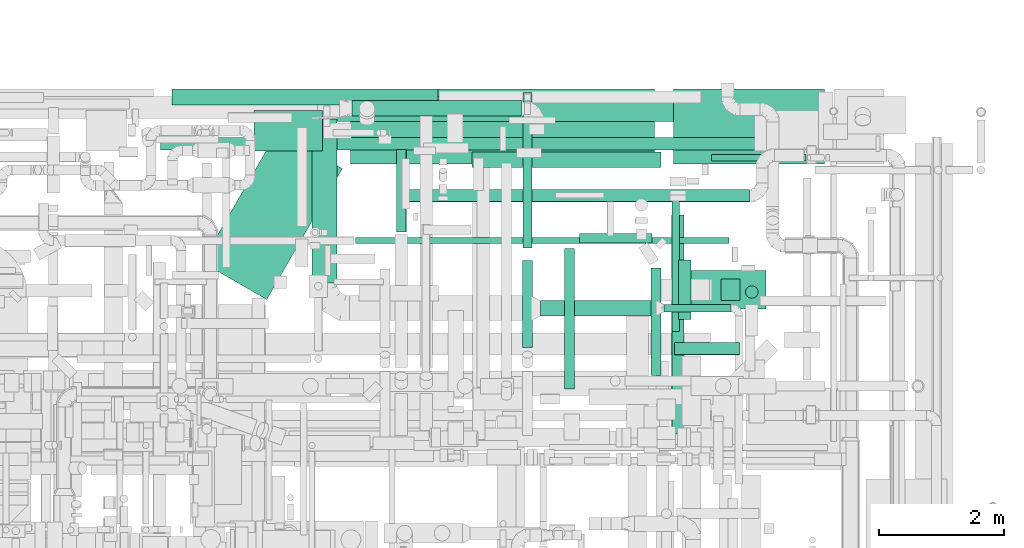
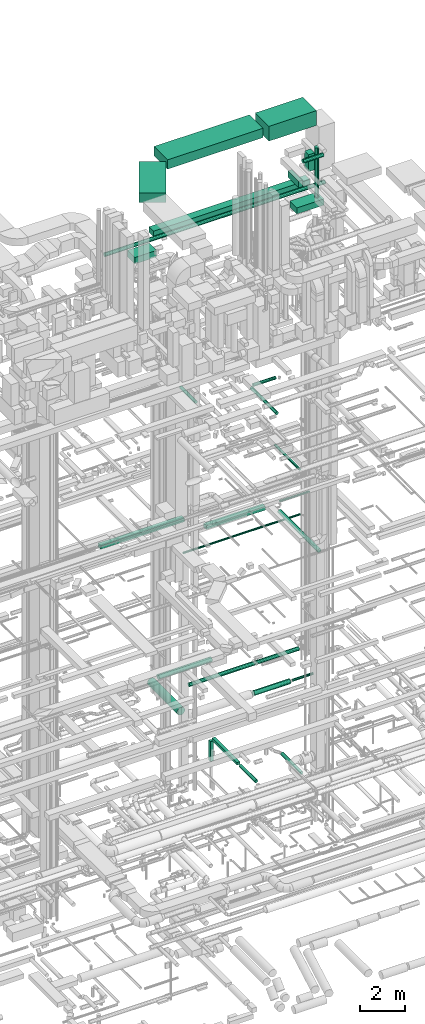
# One storey, part 77 of 337: 29 flow segments.
"""IFC2X3 building model written with IfcOpenShell, lengths in millimetres."""

from ifc_helpers import new_model, entity, si_unit, converted_unit, derived_unit, direction, frame, origin, origin_2d_with_axis, place, context, subcontext, project, spatial, rectangle, circle, extrude, type_object, element, save


model = new_model("IFC2X3")

# Units and contexts
model_context = context("Model", 3, precision=0.01, world=origin(), true_north=direction((6.12303176911189e-17, 1.0)))
body_context = subcontext(model_context, "Body", "Model", "MODEL_VIEW")
ifc_project = project(units=[si_unit("LENGTHUNIT", "METRE", prefix="MILLI"), si_unit("AREAUNIT", "SQUARE_METRE"), si_unit("VOLUMEUNIT", "CUBIC_METRE"), converted_unit("PLANEANGLEUNIT", "DEGREE", entity("IfcRatioMeasure", 0.0174532925199433), si_unit("PLANEANGLEUNIT", "RADIAN"), dimensions=[0, 0, 0, 0, 0, 0, 0]), si_unit("MASSUNIT", "GRAM", prefix="KILO"), derived_unit("MASSDENSITYUNIT", [(si_unit("MASSUNIT", "GRAM", prefix="KILO"), 1), (si_unit("LENGTHUNIT", "METRE"), -3)]), derived_unit("MOMENTOFINERTIAUNIT", [(si_unit("LENGTHUNIT", "METRE"), 4)]), si_unit("TIMEUNIT", "SECOND"), si_unit("FREQUENCYUNIT", "HERTZ"), si_unit("THERMODYNAMICTEMPERATUREUNIT", "DEGREE_CELSIUS"), derived_unit("THERMALTRANSMITTANCEUNIT", [(si_unit("MASSUNIT", "GRAM", prefix="KILO"), 1), (si_unit("THERMODYNAMICTEMPERATUREUNIT", "KELVIN"), -1), (si_unit("TIMEUNIT", "SECOND"), -3)]), derived_unit("VOLUMETRICFLOWRATEUNIT", [(si_unit("LENGTHUNIT", "METRE"), 3), (si_unit("TIMEUNIT", "SECOND"), -1)]), derived_unit("MASSFLOWRATEUNIT", [(si_unit("MASSUNIT", "GRAM", prefix="KILO"), 1), (si_unit("TIMEUNIT", "SECOND"), -1)]), derived_unit("ROTATIONALFREQUENCYUNIT", [(si_unit("TIMEUNIT", "SECOND"), -1)]), si_unit("ELECTRICCURRENTUNIT", "AMPERE"), si_unit("ELECTRICVOLTAGEUNIT", "VOLT"), si_unit("POWERUNIT", "WATT"), si_unit("FORCEUNIT", "NEWTON", prefix="KILO"), si_unit("ILLUMINANCEUNIT", "LUX"), si_unit("LUMINOUSFLUXUNIT", "LUMEN"), si_unit("LUMINOUSINTENSITYUNIT", "CANDELA"), derived_unit("USERDEFINED", [(si_unit("MASSUNIT", "GRAM", prefix="KILO"), -1), (si_unit("LENGTHUNIT", "METRE"), -2), (si_unit("TIMEUNIT", "SECOND"), 3), (si_unit("LUMINOUSFLUXUNIT", "LUMEN"), 1)]), derived_unit("LINEARVELOCITYUNIT", [(si_unit("LENGTHUNIT", "METRE"), 1), (si_unit("TIMEUNIT", "SECOND"), -1)]), si_unit("PRESSUREUNIT", "PASCAL"), derived_unit("USERDEFINED", [(si_unit("LENGTHUNIT", "METRE"), -2), (si_unit("MASSUNIT", "GRAM", prefix="KILO"), 1), (si_unit("TIMEUNIT", "SECOND"), -2)]), derived_unit("LINEARFORCEUNIT", [(si_unit("MASSUNIT", "GRAM", prefix="KILO"), 1), (si_unit("LENGTHUNIT", "METRE"), 1), (si_unit("TIMEUNIT", "SECOND"), -2), (si_unit("LENGTHUNIT", "METRE"), -1)]), derived_unit("PLANARFORCEUNIT", [(si_unit("MASSUNIT", "GRAM", prefix="KILO"), 1), (si_unit("LENGTHUNIT", "METRE"), 1), (si_unit("TIMEUNIT", "SECOND"), -2), (si_unit("LENGTHUNIT", "METRE"), -2)])], contexts=[model_context])

# Site, building, storey
site_placement = place(None, origin())
site = spatial("IfcSite", under=ifc_project, at=site_placement, CompositionType="ELEMENT")
building_placement = place(site_placement, origin())
building = spatial("IfcBuilding", under=site, at=building_placement, CompositionType="ELEMENT")
storey_placement = place(building_placement, origin())
storey = spatial("IfcBuildingStorey", under=building, at=storey_placement, CompositionType="ELEMENT", Elevation=0.0)

# Flow segments
duct_segment_type_1 = type_object("IfcDuctSegmentType", PredefinedType="NOTDEFINED")
flow_segment_1_placement = place(storey_placement, frame((58389.14, 17556.57, -925.0)))
element("IfcFlowSegment", 1, at=flow_segment_1_placement, inside=storey, type_object=duct_segment_type_1, context=body_context, shape_type="SweptSolid", body=[
    extrude(rectangle(XDim=2192.29689275001, YDim=150.000000000001, at=origin_2d_with_axis()), frame((75.0, 1096.15, 0.0), z_axis=(0.0, 0.0, 1.0), x_axis=(0.0, 1.0, 0.0)), (0.0, 0.0, 1.0), 150.0),
])
flow_segment_2_placement = place(storey_placement, frame((58389.14, 19898.87, -2155.0)))
element("IfcFlowSegment", 2, at=flow_segment_2_placement, inside=storey, type_object=duct_segment_type_1, context=body_context, shape_type="SweptSolid", body=[
    extrude(rectangle(XDim=150.000000000001, YDim=150.000000000001, at=origin_2d_with_axis()), frame((75.0, 75.0, 0.0), z_axis=(0.0, 0.0, 1.0), x_axis=(-1.0, 0.0, 0.0)), (0.0, 0.0, 1.0), 1080.00000000006),
])
flow_segment_3_placement = place(storey_placement, frame((57579.84, 18847.07, 11300.0)))
element("IfcFlowSegment", 3, at=flow_segment_3_placement, inside=storey, type_object=duct_segment_type_1, context=body_context, shape_type="SweptSolid", body=[
    extrude(rectangle(XDim=3019.0, YDim=249.999999999999, at=origin_2d_with_axis()), frame((1509.5, 125.0, 0.0), z_axis=(0.0, 0.0, 1.0), x_axis=(-1.0, 0.0, 0.0)), (0.0, 0.0, 1.0), 200.000000000002),
])
flow_segment_4_placement = place(storey_placement, frame((52773.84, 19851.06, 11300.0)))
element("IfcFlowSegment", 4, at=flow_segment_4_placement, inside=storey, type_object=duct_segment_type_1, context=body_context, shape_type="SweptSolid", body=[
    extrude(rectangle(XDim=4255.99999999999, YDim=249.999999999999, at=origin_2d_with_axis()), frame((2128.0, 125.0, 0.0)), (0.0, 0.0, 1.0), 200.000000000002),
])
flow_segment_5_placement = place(storey_placement, frame((55301.64, 19583.98, 27450.0)))
element("IfcFlowSegment", 5, at=flow_segment_5_placement, inside=storey, type_object=duct_segment_type_1, context=body_context, shape_type="SweptSolid", body=[
    extrude(rectangle(XDim=7989.17895112762, YDim=400.0, at=origin_2d_with_axis()), frame((3994.59, 200.0, 0.0)), (0.0, 0.0, 1.0), 300.000000000001),
])
flow_segment_6_placement = place(storey_placement, frame((55631.15, 18904.6, 31400.0)))
element("IfcFlowSegment", 6, at=flow_segment_6_placement, inside=storey, type_object=duct_segment_type_1, context=body_context, shape_type="SweptSolid", body=[
    extrude(rectangle(XDim=4870.01416741954, YDim=1200.0, at=origin_2d_with_axis()), frame((2435.01, 600.0, 0.0)), (0.0, 0.0, 1.0), 499.999999999999),
])
flow_segment_7_placement = place(storey_placement, frame((60801.17, 18904.6, 31100.0)))
element("IfcFlowSegment", 7, at=flow_segment_7_placement, inside=storey, type_object=duct_segment_type_1, context=body_context, shape_type="SweptSolid", body=[
    extrude(rectangle(XDim=2422.00000000014, YDim=1200.0, at=origin_2d_with_axis()), frame((1211.0, 600.0, 0.0), z_axis=(0.0, 0.0, 1.0), x_axis=(-1.0, 0.0, 0.0)), (0.0, 0.0, 1.0), 800.0),
])
flow_segment_8_placement = place(storey_placement, frame((53251.97, 16733.74, 31400.0)))
element("IfcFlowSegment", 8, at=flow_segment_8_placement, inside=storey, type_object=duct_segment_type_1, context=body_context, shape_type="SweptSolid", body=[
    extrude(rectangle(XDim=2420.09070296274, YDim=1200.0, at=origin_2d_with_axis()), frame((1124.64, 1347.93, 0.0), z_axis=(0.0, 0.0, 1.0), x_axis=(0.500000000000004, 0.866025403784436, 0.0)), (0.0, 0.0, 1.0), 499.999999999999),
])
flow_segment_9_placement = place(storey_placement, frame((54083.2, 19108.98, 26700.0)))
element("IfcFlowSegment", 9, at=flow_segment_9_placement, inside=storey, type_object=duct_segment_type_1, context=body_context, shape_type="SweptSolid", body=[
    extrude(rectangle(XDim=1100.0, YDim=650.0, at=origin_2d_with_axis()), frame((550.0, 325.0, 0.0)), (0.0, 0.0, 1.0), 349.999999999998),
])
flow_segment_10_placement = place(storey_placement, frame((60885.21, 16580.46, 28547.0)))
element("IfcFlowSegment", 10, at=flow_segment_10_placement, inside=storey, type_object=duct_segment_type_1, context=body_context, shape_type="SweptSolid", body=[
    extrude(rectangle(XDim=1400.0, YDim=620.0, at=origin_2d_with_axis()), frame((700.0, 310.0, 0.0)), (0.0, 0.0, 1.0), 330.000000000003),
])
duct_segment_type_2 = type_object("IfcDuctSegmentType", PredefinedType="NOTDEFINED")
flow_segment_11_placement = place(storey_placement, frame((60437.78, 15518.96, -931.6)))
element("IfcFlowSegment", 11, at=flow_segment_11_placement, inside=storey, type_object=duct_segment_type_2, context=body_context, shape_type="SweptSolid", body=[
    extrude(circle(Radius=80.0, at=origin_2d_with_axis()), frame((81.6, 0.0, 81.6), z_axis=(0.0, 1.0, 0.0), x_axis=(-1.0, 0.0, 0.0)), (0.0, 0.0, 1.0), 1724.30874543245),
])
flow_segment_12_placement = place(storey_placement, frame((61408.84, 18952.95, 11348.4)))
element("IfcFlowSegment", 12, at=flow_segment_12_placement, inside=storey, type_object=duct_segment_type_2, context=body_context, shape_type="SweptSolid", body=[
    extrude(circle(Radius=50.0, at=origin_2d_with_axis()), frame((0.0, 51.6, 51.6), z_axis=(1.0, 0.0, 0.0), x_axis=(0.0, 1.0, 0.0)), (0.0, 0.0, 1.0), 1514.13824156444),
])
flow_segment_13_placement = place(storey_placement, frame((60772.49, 16220.0, 14935.9)))
element("IfcFlowSegment", 13, at=flow_segment_13_placement, inside=storey, type_object=duct_segment_type_2, context=body_context, shape_type="SweptSolid", body=[
    extrude(circle(Radius=62.5, at=origin_2d_with_axis()), frame((64.1, 0.0, 64.1), z_axis=(0.0, 1.0, 0.0), x_axis=(1.0, 0.0, 0.0)), (0.0, 0.0, 1.0), 2179.99999999996),
])
flow_segment_14_placement = place(storey_placement, frame((55712.3, 17626.51, 11348.4)))
element("IfcFlowSegment", 14, at=flow_segment_14_placement, inside=storey, type_object=duct_segment_type_2, context=body_context, shape_type="SweptSolid", body=[
    extrude(circle(Radius=50.0, at=origin_2d_with_axis()), frame((0.0, 51.6, 51.6), z_axis=(1.0, 0.0, 0.0), x_axis=(0.0, -1.0, 0.0)), (0.0, 0.0, 1.0), 5974.99999999999),
])
flow_segment_15_placement = place(storey_placement, frame((55655.84, 19669.65, 3323.4)))
element("IfcFlowSegment", 15, at=flow_segment_15_placement, inside=storey, type_object=duct_segment_type_2, context=body_context, shape_type="SweptSolid", body=[
    extrude(circle(Radius=125.0, at=origin_2d_with_axis()), frame((0.0, 126.6, 126.6), z_axis=(1.0, 0.0, 0.0), x_axis=(0.0, 1.0, 0.0)), (0.0, 0.0, 1.0), 2709.99999999997),
])
flow_segment_16_placement = place(storey_placement, frame((60772.24, 14580.15, 11498.4)))
element("IfcFlowSegment", 16, at=flow_segment_16_placement, inside=storey, type_object=duct_segment_type_2, context=body_context, shape_type="SweptSolid", body=[
    extrude(circle(Radius=100.0, at=origin_2d_with_axis()), frame((101.6, 0.0, 101.6), z_axis=(0.0, 1.0, 0.0), x_axis=(-1.0, 0.0, 0.0)), (0.0, 0.0, 1.0), 3506.41016299892),
])
flow_segment_17_placement = place(storey_placement, frame((56362.71, 17815.52, 19118.4)))
element("IfcFlowSegment", 17, at=flow_segment_17_placement, inside=storey, type_object=duct_segment_type_2, context=body_context, shape_type="SweptSolid", body=[
    extrude(circle(Radius=80.0, at=origin_2d_with_axis()), frame((81.6, 0.0, 81.6), z_axis=(0.0, 1.0, 0.0), x_axis=(1.0, 0.0, 0.0)), (0.0, 0.0, 1.0), 1324.68749999998),
])
flow_segment_18_placement = place(storey_placement, frame((59053.0, 15299.34, 19102.97)))
element("IfcFlowSegment", 18, at=flow_segment_18_placement, inside=storey, type_object=duct_segment_type_2, context=body_context, shape_type="SweptSolid", body=[
    extrude(circle(Radius=80.0, at=origin_2d_with_axis()), frame((81.6, 0.0, 81.6), z_axis=(0.0, 1.0, 0.0), x_axis=(-1.0, 0.0, 0.0)), (0.0, 0.0, 1.0), 2254.72055554317),
])
flow_segment_19_placement = place(storey_placement, frame((59294.6, 17632.47, 19102.97)))
element("IfcFlowSegment", 19, at=flow_segment_19_placement, inside=storey, type_object=duct_segment_type_2, context=body_context, shape_type="SweptSolid", body=[
    extrude(circle(Radius=80.0, at=origin_2d_with_axis()), frame((0.0, 81.6, 81.6), z_axis=(1.0, 0.0, 0.0), x_axis=(0.0, -1.0, 0.0)), (0.0, 0.0, 1.0), 1161.22583002072),
])
flow_segment_20_placement = place(storey_placement, frame((52590.65, 19126.53, 27548.4)))
element("IfcFlowSegment", 20, at=flow_segment_20_placement, inside=storey, type_object=duct_segment_type_2, context=body_context, shape_type="SweptSolid", body=[
    extrude(circle(Radius=100.0, at=origin_2d_with_axis()), frame((0.0, 101.6, 101.6), z_axis=(1.0, 0.0, 0.0), x_axis=(0.0, 1.0, 0.0)), (0.0, 0.0, 1.0), 11251.9965340593),
])
flow_segment_21_placement = place(storey_placement, frame((60820.03, 15848.01, 31698.4)))
element("IfcFlowSegment", 21, at=flow_segment_21_placement, inside=storey, type_object=duct_segment_type_2, context=body_context, shape_type="SweptSolid", body=[
    extrude(circle(Radius=100.0, at=origin_2d_with_axis()), frame((0.0, 101.6, 101.6), z_axis=(1.0, 0.0, 0.0), x_axis=(0.0, -1.0, 0.0)), (0.0, 0.0, 1.0), 1035.66528063072),
])
flow_segment_22_placement = place(storey_placement, frame((61954.1, 16753.19, 28897.0)))
element("IfcFlowSegment", 22, at=flow_segment_22_placement, inside=storey, type_object=duct_segment_type_2, context=body_context, shape_type="SweptSolid", body=[
    extrude(circle(Radius=100.0, at=origin_2d_with_axis()), frame((101.6, 101.6, 0.0), z_axis=(0.0, 0.0, 1.0), x_axis=(-1.0, 0.0, 0.0)), (0.0, 0.0, 1.0), 2702.99999999996),
])
flow_segment_23_placement = place(storey_placement, frame((55012.15, 16996.24, 3248.4)))
element("IfcFlowSegment", 23, at=flow_segment_23_placement, inside=storey, type_object=duct_segment_type_2, context=body_context, shape_type="SweptSolid", body=[
    extrude(circle(Radius=200.0, at=origin_2d_with_axis()), frame((201.6, 0.0, 201.6), z_axis=(0.0, 1.0, 0.0), x_axis=(1.0, 0.0, 0.0)), (0.0, 0.0, 1.0), 2630.0),
])
flow_segment_24_placement = place(storey_placement, frame((58672.05, 16469.65, 3323.4)))
element("IfcFlowSegment", 24, at=flow_segment_24_placement, inside=storey, type_object=duct_segment_type_2, context=body_context, shape_type="SweptSolid", body=[
    extrude(circle(Radius=125.0, at=origin_2d_with_axis()), frame((0.0, 126.6, 126.6), z_axis=(1.0, 0.0, 0.0), x_axis=(0.0, -1.0, 0.0)), (0.0, 0.0, 1.0), 1849.99999999999),
])
flow_segment_25_placement = place(storey_placement, frame((60647.05, 16532.15, 3385.9)))
element("IfcFlowSegment", 25, at=flow_segment_25_placement, inside=storey, type_object=duct_segment_type_2, context=body_context, shape_type="SweptSolid", body=[
    extrude(circle(Radius=62.5, at=origin_2d_with_axis()), frame((0.0, 64.1, 64.1), z_axis=(1.0, 0.0, 0.0), x_axis=(0.0, -1.0, 0.0)), (0.0, 0.0, 1.0), 1075.00000000002),
])
flow_segment_26_placement = place(storey_placement, frame((56418.88, 18297.14, 3498.4)))
element("IfcFlowSegment", 26, at=flow_segment_26_placement, inside=storey, type_object=duct_segment_type_2, context=body_context, shape_type="SweptSolid", body=[
    extrude(circle(Radius=100.0, at=origin_2d_with_axis()), frame((0.0, 101.6, 101.6), z_axis=(1.0, 0.0, 0.0), x_axis=(0.0, 1.0, 0.0)), (0.0, 0.0, 1.0), 5600.00000000001),
])
flow_segment_27_placement = place(storey_placement, frame((58382.55, 15964.53, -931.6)))
element("IfcFlowSegment", 27, at=flow_segment_27_placement, inside=storey, type_object=duct_segment_type_2, context=body_context, shape_type="SweptSolid", body=[
    extrude(circle(Radius=80.0, at=origin_2d_with_axis()), frame((81.6, 0.0, 81.6), z_axis=(0.0, 1.0, 0.0), x_axis=(-1.0, 0.0, 0.0)), (0.0, 0.0, 1.0), 1392.04452484468),
])
duct_segment_type_3 = type_object("IfcDuctSegmentType", PredefinedType="NOTDEFINED")
flow_segment_28_placement = place(storey_placement, frame((61566.06, 16715.46, 30512.0)))
element("IfcFlowSegment", 28, at=flow_segment_28_placement, inside=storey, type_object=duct_segment_type_3, context=body_context, shape_type="SweptSolid", body=[
    extrude(rectangle(XDim=300.000000000001, YDim=350.000000000001, at=origin_2d_with_axis()), frame((150.0, 175.0, 0.0), z_axis=(0.0, 0.0, 1.0), x_axis=(-1.0, 0.0, 0.0)), (0.0, 0.0, 1.0), 913.0),
])
flow_segment_29_placement = place(storey_placement, frame((60884.05, 16415.46, 30062.0)))
element("IfcFlowSegment", 29, at=flow_segment_29_placement, inside=storey, type_object=duct_segment_type_3, context=body_context, shape_type="SweptSolid", body=[
    extrude(rectangle(XDim=197.532480584659, YDim=950.000000000001, at=origin_2d_with_axis()), frame((98.77, 475.0, 0.0)), (0.0, 0.0, 1.0), 349.999999999998),
])

save(model, "model.ifc")
